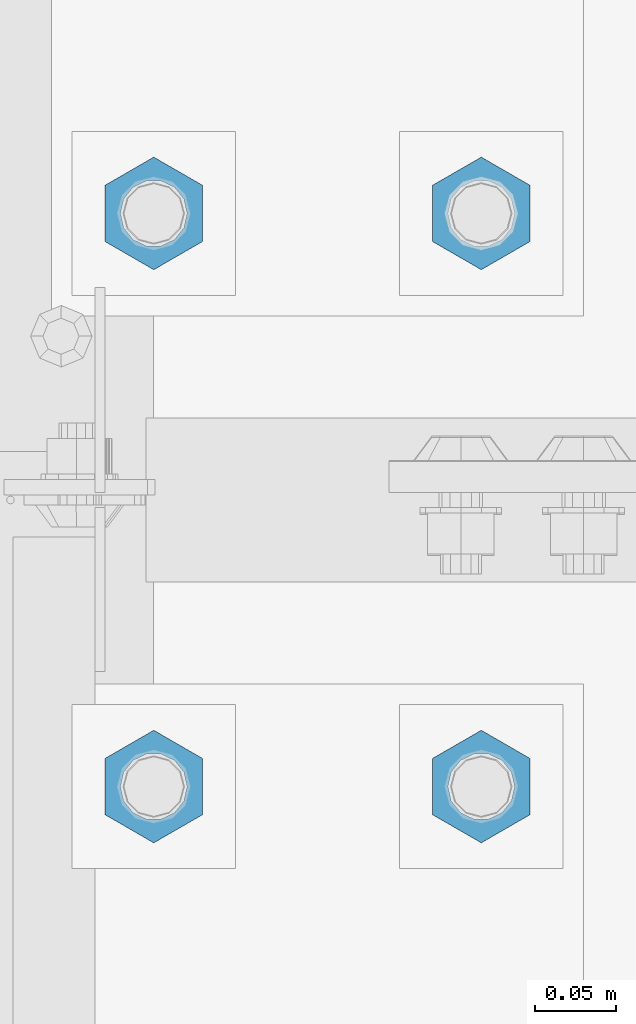
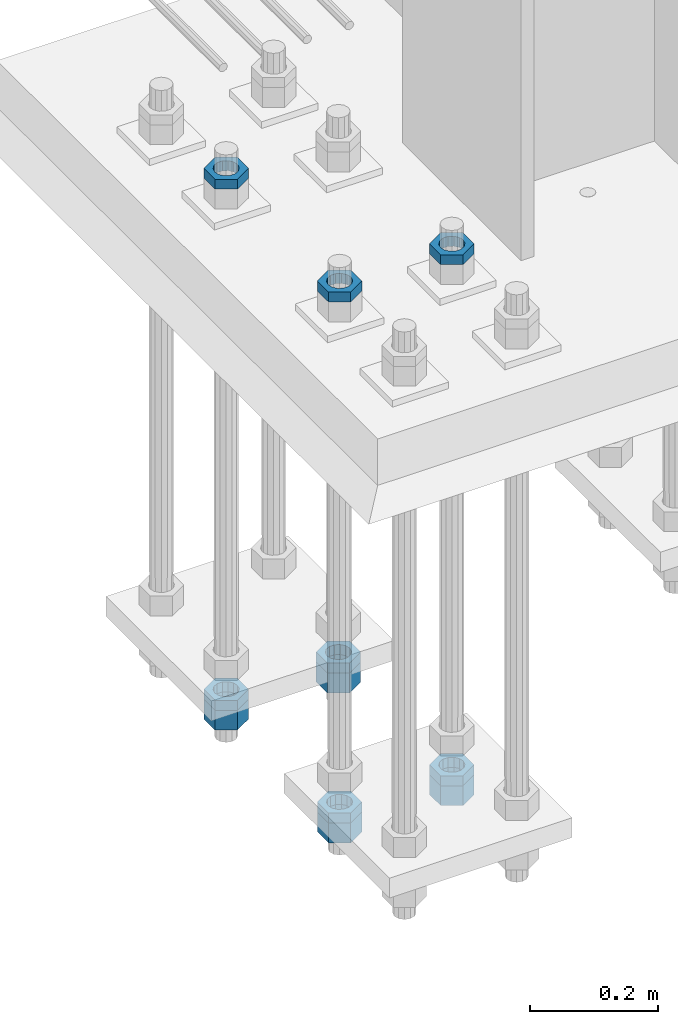
# One storey, part 2804 of 3843: 11 beams, 1 element without a shape of its own.
"""IFC2X3 building model written with IfcOpenShell, lengths in millimetres."""

from ifc_helpers import new_model, si_unit, frame, origin_with_axes, place, context, subcontext, project, spatial, faceted_brep, material, type_object, element, aggregate, save


model = new_model("IFC2X3")

# Units and contexts
model_context = context("Model", 3, precision=1e-05, world=origin_with_axes())
body_context = subcontext(model_context, "Body", "Model", "MODEL_VIEW")
ifc_project = project(units=[si_unit("LENGTHUNIT", "METRE", prefix="MILLI"), si_unit("AREAUNIT", "SQUARE_METRE"), si_unit("VOLUMEUNIT", "CUBIC_METRE"), si_unit("MASSUNIT", "GRAM", prefix="KILO"), si_unit("TIMEUNIT", "SECOND"), si_unit("PLANEANGLEUNIT", "RADIAN"), si_unit("SOLIDANGLEUNIT", "STERADIAN"), si_unit("THERMODYNAMICTEMPERATUREUNIT", "DEGREE_CELSIUS"), si_unit("LUMINOUSINTENSITYUNIT", "LUMEN")], contexts=[model_context])

# Site, building, storey
site_placement = place(None, origin_with_axes())
site = spatial("IfcSite", under=ifc_project, at=site_placement, CompositionType="ELEMENT")
building_placement = place(site_placement, origin_with_axes())
building = spatial("IfcBuilding", under=site, at=building_placement, Name="Undefined", CompositionType="ELEMENT")
storey_placement = place(building_placement, origin_with_axes())
storey = spatial("IfcBuildingStorey", under=building, at=storey_placement, Name="Undefined", CompositionType="ELEMENT", Elevation=0.0)

# Assembly, beams
assembly_placement = place(storey_placement, origin_with_axes())
assembly = element("IfcElementAssembly", 1, at=assembly_placement, inside=storey, Name="TEMPLATE", AssemblyPlace="NOTDEFINED", PredefinedType="RIGID_FRAME")
ifc_material = material(Name="STEEL/A572-50")
beam_type_1 = type_object("IfcBeamType", Name="1-1/2_HEAVY_HEX_NUT", PredefinedType="NOTDEFINED")
beam_1_placement = place(assembly_placement, frame((76504.799987793, 14820.8999969482, 29203.6500015259), z_axis=(1.0, 0.0, 0.0), x_axis=(0.0, 0.0, -1.0)))
beam_1 = element("IfcBeam", 2, at=beam_1_placement, type_object=beam_type_1, material=ifc_material, Name="NUT", ObjectType="1-1/2_HEAVY_HEX_NUT", context=body_context, shape_type="Brep", body=[
    faceted_brep([(0.0, -34.9199981689453, 0.0), (0.0, -17.4599990844727, -30.25), (38.0999999999985, -17.4599990844727, -30.25), (38.0999999999985, -34.9199981689453, 0.0), (0.0, 17.4599990844727, -30.25), (38.0999999999985, 17.4599990844727, -30.25), (0.0, 34.9199981689453, 0.0), (38.0999999999985, 34.9199981689453, 0.0), (0.0, 17.4599990844727, 30.25), (38.0999999999985, 17.4599990844727, 30.25), (0.0, -17.4599990844727, 30.25), (38.0999999999985, -17.4599990844727, 30.25), (0.0, 0.0, 20.6399993896484), (0.0, 8.9553601105581, 18.5959968835959), (38.0999999999985, 8.9553601105581, 18.5959968835959), (38.0999999999985, 0.0, 20.6399993896484), (0.0, 16.1370013209525, 12.8688291298167), (38.0999999999985, 16.1370013209525, 12.8688291298167), (0.0, 20.1225115123816, 4.59283194104501), (38.0999999999985, 20.1225115123816, 4.59283194104501), (0.0, 20.1225115123816, -4.59283194104501), (38.0999999999985, 20.1225115123816, -4.59283194104501), (0.0, 16.1370013209525, -12.8688291298167), (38.0999999999985, 16.1370013209525, -12.8688291298167), (0.0, 8.9553601105581, -18.5959968835959), (38.0999999999985, 8.9553601105581, -18.5959968835959), (0.0, 0.0, -20.6399993896484), (38.0999999999985, 0.0, -20.6399993896484), (0.0, -8.9553601105581, -18.5959968835959), (38.0999999999985, -8.9553601105581, -18.5959968835959), (0.0, -16.1370013209525, -12.8688291298167), (38.0999999999985, -16.1370013209525, -12.8688291298167), (0.0, -20.1225115123816, -4.59283194104501), (38.0999999999985, -20.1225115123816, -4.59283194104501), (0.0, -20.1225115123816, 4.59283194104501), (38.0999999999985, -20.1225115123816, 4.59283194104501), (0.0, -16.1370013209525, 12.8688291298167), (38.0999999999985, -16.1370013209525, 12.8688291298167), (0.0, -8.9553601105581, 18.5959968835959), (38.0999999999985, -8.9553601105581, 18.5959968835959)], [[[0, 1, 2, 3]], [[1, 4, 5, 2]], [[4, 6, 7, 5]], [[6, 8, 9, 7]], [[8, 10, 11, 9]], [[10, 0, 3, 11]], [[12, 13, 14, 15]], [[13, 16, 17, 14]], [[16, 18, 19, 17]], [[18, 20, 21, 19]], [[20, 22, 23, 21]], [[22, 24, 25, 23]], [[24, 26, 27, 25]], [[26, 28, 29, 27]], [[28, 30, 31, 29]], [[30, 32, 33, 31]], [[32, 34, 35, 33]], [[34, 36, 37, 35]], [[36, 38, 39, 37]], [[38, 12, 15, 39]], [[5, 7, 9, 11, 3, 2], [17, 19, 21, 23, 25, 27, 29, 31, 33, 35, 37, 39, 15, 14]], [[10, 8, 6, 4, 1, 0], [38, 36, 34, 32, 30, 28, 26, 24, 22, 20, 18, 16, 13, 12]]]),
])
beam_2_placement = place(assembly_placement, frame((76708.0, 14820.8999969482, 29203.6500015259), z_axis=(1.0, 0.0, 0.0), x_axis=(0.0, 0.0, -1.0)))
beam_2 = element("IfcBeam", 3, at=beam_2_placement, type_object=beam_type_1, material=ifc_material, Name="NUT", ObjectType="1-1/2_HEAVY_HEX_NUT", context=body_context, shape_type="Brep", body=[
    faceted_brep([(0.0, -34.9199981689453, 0.0), (0.0, -17.4599990844727, -30.25), (38.0999999999985, -17.4599990844727, -30.25), (38.0999999999985, -34.9199981689453, 0.0), (0.0, 17.4599990844727, -30.25), (38.0999999999985, 17.4599990844727, -30.25), (0.0, 34.9199981689453, 0.0), (38.0999999999985, 34.9199981689453, 0.0), (0.0, 17.4599990844727, 30.25), (38.0999999999985, 17.4599990844727, 30.25), (0.0, -17.4599990844727, 30.25), (38.0999999999985, -17.4599990844727, 30.25), (0.0, 0.0, 20.6399993896484), (0.0, 8.9553601105581, 18.5959968835959), (38.0999999999985, 8.9553601105581, 18.5959968835959), (38.0999999999985, 0.0, 20.6399993896484), (0.0, 16.1370013209525, 12.8688291298167), (38.0999999999985, 16.1370013209525, 12.8688291298167), (0.0, 20.1225115123816, 4.59283194104501), (38.0999999999985, 20.1225115123816, 4.59283194104501), (0.0, 20.1225115123816, -4.59283194104501), (38.0999999999985, 20.1225115123816, -4.59283194104501), (0.0, 16.1370013209525, -12.8688291298167), (38.0999999999985, 16.1370013209525, -12.8688291298167), (0.0, 8.9553601105581, -18.5959968835959), (38.0999999999985, 8.9553601105581, -18.5959968835959), (0.0, 0.0, -20.6399993896484), (38.0999999999985, 0.0, -20.6399993896484), (0.0, -8.9553601105581, -18.5959968835959), (38.0999999999985, -8.9553601105581, -18.5959968835959), (0.0, -16.1370013209525, -12.8688291298167), (38.0999999999985, -16.1370013209525, -12.8688291298167), (0.0, -20.1225115123816, -4.59283194104501), (38.0999999999985, -20.1225115123816, -4.59283194104501), (0.0, -20.1225115123816, 4.59283194104501), (38.0999999999985, -20.1225115123816, 4.59283194104501), (0.0, -16.1370013209525, 12.8688291298167), (38.0999999999985, -16.1370013209525, 12.8688291298167), (0.0, -8.9553601105581, 18.5959968835959), (38.0999999999985, -8.9553601105581, 18.5959968835959)], [[[0, 1, 2, 3]], [[1, 4, 5, 2]], [[4, 6, 7, 5]], [[6, 8, 9, 7]], [[8, 10, 11, 9]], [[10, 0, 3, 11]], [[12, 13, 14, 15]], [[13, 16, 17, 14]], [[16, 18, 19, 17]], [[18, 20, 21, 19]], [[20, 22, 23, 21]], [[22, 24, 25, 23]], [[24, 26, 27, 25]], [[26, 28, 29, 27]], [[28, 30, 31, 29]], [[30, 32, 33, 31]], [[32, 34, 35, 33]], [[34, 36, 37, 35]], [[36, 38, 39, 37]], [[38, 12, 15, 39]], [[5, 7, 9, 11, 3, 2], [17, 19, 21, 23, 25, 27, 29, 31, 33, 35, 37, 39, 15, 14]], [[10, 8, 6, 4, 1, 0], [38, 36, 34, 32, 30, 28, 26, 24, 22, 20, 18, 16, 13, 12]]]),
])
beam_3_placement = place(assembly_placement, frame((76504.799987793, 15176.5, 29203.6500015259), z_axis=(1.0, 0.0, 0.0), x_axis=(0.0, 0.0, -1.0)))
beam_3 = element("IfcBeam", 4, at=beam_3_placement, type_object=beam_type_1, material=ifc_material, Name="NUT", ObjectType="1-1/2_HEAVY_HEX_NUT", context=body_context, shape_type="Brep", body=[
    faceted_brep([(0.0, -34.9199981689453, 0.0), (0.0, -17.4599990844727, -30.25), (38.0999999999985, -17.4599990844727, -30.25), (38.0999999999985, -34.9199981689453, 0.0), (0.0, 17.4599990844727, -30.25), (38.0999999999985, 17.4599990844727, -30.25), (0.0, 34.9199981689453, 0.0), (38.0999999999985, 34.9199981689453, 0.0), (0.0, 17.4599990844727, 30.25), (38.0999999999985, 17.4599990844727, 30.25), (0.0, -17.4599990844727, 30.25), (38.0999999999985, -17.4599990844727, 30.25), (0.0, 0.0, 20.6399993896484), (0.0, 8.9553601105581, 18.5959968835959), (38.0999999999985, 8.9553601105581, 18.5959968835959), (38.0999999999985, 0.0, 20.6399993896484), (0.0, 16.1370013209525, 12.8688291298167), (38.0999999999985, 16.1370013209525, 12.8688291298167), (0.0, 20.1225115123816, 4.59283194104501), (38.0999999999985, 20.1225115123816, 4.59283194104501), (0.0, 20.1225115123816, -4.59283194104501), (38.0999999999985, 20.1225115123816, -4.59283194104501), (0.0, 16.1370013209525, -12.8688291298167), (38.0999999999985, 16.1370013209525, -12.8688291298167), (0.0, 8.9553601105581, -18.5959968835959), (38.0999999999985, 8.9553601105581, -18.5959968835959), (0.0, 0.0, -20.6399993896484), (38.0999999999985, 0.0, -20.6399993896484), (0.0, -8.9553601105581, -18.5959968835959), (38.0999999999985, -8.9553601105581, -18.5959968835959), (0.0, -16.1370013209525, -12.8688291298167), (38.0999999999985, -16.1370013209525, -12.8688291298167), (0.0, -20.1225115123816, -4.59283194104501), (38.0999999999985, -20.1225115123816, -4.59283194104501), (0.0, -20.1225115123816, 4.59283194104501), (38.0999999999985, -20.1225115123816, 4.59283194104501), (0.0, -16.1370013209525, 12.8688291298167), (38.0999999999985, -16.1370013209525, 12.8688291298167), (0.0, -8.9553601105581, 18.5959968835959), (38.0999999999985, -8.9553601105581, 18.5959968835959)], [[[0, 1, 2, 3]], [[1, 4, 5, 2]], [[4, 6, 7, 5]], [[6, 8, 9, 7]], [[8, 10, 11, 9]], [[10, 0, 3, 11]], [[12, 13, 14, 15]], [[13, 16, 17, 14]], [[16, 18, 19, 17]], [[18, 20, 21, 19]], [[20, 22, 23, 21]], [[22, 24, 25, 23]], [[24, 26, 27, 25]], [[26, 28, 29, 27]], [[28, 30, 31, 29]], [[30, 32, 33, 31]], [[32, 34, 35, 33]], [[34, 36, 37, 35]], [[36, 38, 39, 37]], [[38, 12, 15, 39]], [[5, 7, 9, 11, 3, 2], [17, 19, 21, 23, 25, 27, 29, 31, 33, 35, 37, 39, 15, 14]], [[10, 8, 6, 4, 1, 0], [38, 36, 34, 32, 30, 28, 26, 24, 22, 20, 18, 16, 13, 12]]]),
])
beam_4_placement = place(assembly_placement, frame((76708.0, 15176.5, 29203.6500015259), z_axis=(1.0, 0.0, 0.0), x_axis=(0.0, 0.0, -1.0)))
beam_4 = element("IfcBeam", 5, at=beam_4_placement, type_object=beam_type_1, material=ifc_material, Name="NUT", ObjectType="1-1/2_HEAVY_HEX_NUT", context=body_context, shape_type="Brep", body=[
    faceted_brep([(0.0, -34.9199981689453, 0.0), (0.0, -17.4599990844727, -30.25), (38.0999999999985, -17.4599990844727, -30.25), (38.0999999999985, -34.9199981689453, 0.0), (0.0, 17.4599990844727, -30.25), (38.0999999999985, 17.4599990844727, -30.25), (0.0, 34.9199981689453, 0.0), (38.0999999999985, 34.9199981689453, 0.0), (0.0, 17.4599990844727, 30.25), (38.0999999999985, 17.4599990844727, 30.25), (0.0, -17.4599990844727, 30.25), (38.0999999999985, -17.4599990844727, 30.25), (0.0, 0.0, 20.6399993896484), (0.0, 8.9553601105581, 18.5959968835959), (38.0999999999985, 8.9553601105581, 18.5959968835959), (38.0999999999985, 0.0, 20.6399993896484), (0.0, 16.1370013209525, 12.8688291298167), (38.0999999999985, 16.1370013209525, 12.8688291298167), (0.0, 20.1225115123816, 4.59283194104501), (38.0999999999985, 20.1225115123816, 4.59283194104501), (0.0, 20.1225115123816, -4.59283194104501), (38.0999999999985, 20.1225115123816, -4.59283194104501), (0.0, 16.1370013209525, -12.8688291298167), (38.0999999999985, 16.1370013209525, -12.8688291298167), (0.0, 8.9553601105581, -18.5959968835959), (38.0999999999985, 8.9553601105581, -18.5959968835959), (0.0, 0.0, -20.6399993896484), (38.0999999999985, 0.0, -20.6399993896484), (0.0, -8.9553601105581, -18.5959968835959), (38.0999999999985, -8.9553601105581, -18.5959968835959), (0.0, -16.1370013209525, -12.8688291298167), (38.0999999999985, -16.1370013209525, -12.8688291298167), (0.0, -20.1225115123816, -4.59283194104501), (38.0999999999985, -20.1225115123816, -4.59283194104501), (0.0, -20.1225115123816, 4.59283194104501), (38.0999999999985, -20.1225115123816, 4.59283194104501), (0.0, -16.1370013209525, 12.8688291298167), (38.0999999999985, -16.1370013209525, 12.8688291298167), (0.0, -8.9553601105581, 18.5959968835959), (38.0999999999985, -8.9553601105581, 18.5959968835959)], [[[0, 1, 2, 3]], [[1, 4, 5, 2]], [[4, 6, 7, 5]], [[6, 8, 9, 7]], [[8, 10, 11, 9]], [[10, 0, 3, 11]], [[12, 13, 14, 15]], [[13, 16, 17, 14]], [[16, 18, 19, 17]], [[18, 20, 21, 19]], [[20, 22, 23, 21]], [[22, 24, 25, 23]], [[24, 26, 27, 25]], [[26, 28, 29, 27]], [[28, 30, 31, 29]], [[30, 32, 33, 31]], [[32, 34, 35, 33]], [[34, 36, 37, 35]], [[36, 38, 39, 37]], [[38, 12, 15, 39]], [[5, 7, 9, 11, 3, 2], [17, 19, 21, 23, 25, 27, 29, 31, 33, 35, 37, 39, 15, 14]], [[10, 8, 6, 4, 1, 0], [38, 36, 34, 32, 30, 28, 26, 24, 22, 20, 18, 16, 13, 12]]]),
])
beam_type_2 = type_object("IfcBeamType", Name="1-1/2_HALF_NUT", PredefinedType="NOTDEFINED")
beam_5_placement = place(assembly_placement, frame((76504.799987793, 14820.8999969482, 29222.7), z_axis=(1.0, 0.0, 0.0), x_axis=(0.0, 0.0, -1.0)))
beam_5 = element("IfcBeam", 6, at=beam_5_placement, type_object=beam_type_2, material=ifc_material, Name="NUT", ObjectType="1-1/2_HALF_NUT", context=body_context, shape_type="Brep", body=[
    faceted_brep([(0.0, -34.9199981689453, 0.0), (0.0, -17.4599990844727, -30.25), (19.0500000000029, -17.4599990844727, -30.25), (19.0500000000029, -34.9199981689453, 0.0), (0.0, 17.4599990844727, -30.25), (19.0500000000029, 17.4599990844727, -30.25), (0.0, 34.9199981689453, 0.0), (19.0500000000029, 34.9199981689453, 0.0), (0.0, 17.4599990844727, 30.25), (19.0500000000029, 17.4599990844727, 30.25), (0.0, -17.4599990844727, 30.25), (19.0500000000029, -17.4599990844727, 30.25), (0.0, 0.0, 20.6399993896484), (0.0, 8.9553601105581, 18.5959968835959), (19.0500000000029, 8.95536011056538, 18.5959968835959), (19.0500000000029, 0.0, 20.6399993896484), (0.0, 16.1370013209525, 12.8688291298167), (19.0500000000029, 16.1370013209489, 12.8688291298167), (0.0, 20.1225115123816, 4.59283194104501), (19.0500000000029, 20.1225115123852, 4.59283194104501), (0.0, 20.1225115123816, -4.59283194104501), (19.0500000000029, 20.1225115123852, -4.59283194104501), (0.0, 16.1370013209525, -12.8688291298167), (19.0500000000029, 16.1370013209489, -12.8688291298167), (0.0, 8.9553601105581, -18.5959968835959), (19.0500000000029, 8.95536011056538, -18.5959968835959), (0.0, 0.0, -20.6399993896484), (19.0500000000029, 0.0, -20.6399993896484), (0.0, -8.9553601105581, -18.5959968835959), (19.0500000000029, -8.95536011056538, -18.5959968835959), (0.0, -16.1370013209525, -12.8688291298167), (19.0500000000029, -16.1370013209489, -12.8688291298167), (0.0, -20.1225115123816, -4.59283194104501), (19.0500000000029, -20.1225115123852, -4.59283194104501), (0.0, -20.1225115123816, 4.59283194104501), (19.0500000000029, -20.1225115123852, 4.59283194104501), (0.0, -16.1370013209525, 12.8688291298167), (19.0500000000029, -16.1370013209489, 12.8688291298167), (0.0, -8.9553601105581, 18.5959968835959), (19.0500000000029, -8.95536011056538, 18.5959968835959)], [[[0, 1, 2, 3]], [[1, 4, 5, 2]], [[4, 6, 7, 5]], [[6, 8, 9, 7]], [[8, 10, 11, 9]], [[10, 0, 3, 11]], [[12, 13, 14, 15]], [[13, 16, 17, 14]], [[16, 18, 19, 17]], [[18, 20, 21, 19]], [[20, 22, 23, 21]], [[22, 24, 25, 23]], [[24, 26, 27, 25]], [[26, 28, 29, 27]], [[28, 30, 31, 29]], [[30, 32, 33, 31]], [[32, 34, 35, 33]], [[34, 36, 37, 35]], [[36, 38, 39, 37]], [[38, 12, 15, 39]], [[5, 7, 9, 11, 3, 2], [17, 19, 21, 23, 25, 27, 29, 31, 33, 35, 37, 39, 15, 14]], [[10, 8, 6, 4, 1, 0], [38, 36, 34, 32, 30, 28, 26, 24, 22, 20, 18, 16, 13, 12]]]),
])
beam_6_placement = place(assembly_placement, frame((76504.799987793, 14820.8999969482, 30219.65), z_axis=(1.0, 0.0, 0.0), x_axis=(0.0, 0.0, -1.0)))
beam_6 = element("IfcBeam", 7, at=beam_6_placement, type_object=beam_type_2, material=ifc_material, Name="NUT", ObjectType="1-1/2_HALF_NUT", context=body_context, shape_type="Brep", body=[
    faceted_brep([(0.0, -34.9199981689453, 0.0), (0.0, -17.4599990844727, -30.25), (19.0500000000029, -17.4599990844727, -30.25), (19.0500000000029, -34.9199981689453, 0.0), (0.0, 17.4599990844727, -30.25), (19.0500000000029, 17.4599990844727, -30.25), (0.0, 34.9199981689453, 0.0), (19.0500000000029, 34.9199981689453, 0.0), (0.0, 17.4599990844727, 30.25), (19.0500000000029, 17.4599990844727, 30.25), (0.0, -17.4599990844727, 30.25), (19.0500000000029, -17.4599990844727, 30.25), (0.0, 0.0, 20.6399993896484), (0.0, 8.9553601105581, 18.5959968835959), (19.0500000000029, 8.95536011056538, 18.5959968835959), (19.0500000000029, 0.0, 20.6399993896484), (0.0, 16.1370013209525, 12.8688291298167), (19.0500000000029, 16.1370013209489, 12.8688291298167), (0.0, 20.1225115123816, 4.59283194104501), (19.0500000000029, 20.1225115123852, 4.59283194104501), (0.0, 20.1225115123816, -4.59283194104501), (19.0500000000029, 20.1225115123852, -4.59283194104501), (0.0, 16.1370013209525, -12.8688291298167), (19.0500000000029, 16.1370013209489, -12.8688291298167), (0.0, 8.9553601105581, -18.5959968835959), (19.0500000000029, 8.95536011056538, -18.5959968835959), (0.0, 0.0, -20.6399993896484), (19.0500000000029, 0.0, -20.6399993896484), (0.0, -8.9553601105581, -18.5959968835959), (19.0500000000029, -8.95536011056538, -18.5959968835959), (0.0, -16.1370013209525, -12.8688291298167), (19.0500000000029, -16.1370013209489, -12.8688291298167), (0.0, -20.1225115123816, -4.59283194104501), (19.0500000000029, -20.1225115123852, -4.59283194104501), (0.0, -20.1225115123816, 4.59283194104501), (19.0500000000029, -20.1225115123852, 4.59283194104501), (0.0, -16.1370013209525, 12.8688291298167), (19.0500000000029, -16.1370013209489, 12.8688291298167), (0.0, -8.9553601105581, 18.5959968835959), (19.0500000000029, -8.95536011056538, 18.5959968835959)], [[[0, 1, 2, 3]], [[1, 4, 5, 2]], [[4, 6, 7, 5]], [[6, 8, 9, 7]], [[8, 10, 11, 9]], [[10, 0, 3, 11]], [[12, 13, 14, 15]], [[13, 16, 17, 14]], [[16, 18, 19, 17]], [[18, 20, 21, 19]], [[20, 22, 23, 21]], [[22, 24, 25, 23]], [[24, 26, 27, 25]], [[26, 28, 29, 27]], [[28, 30, 31, 29]], [[30, 32, 33, 31]], [[32, 34, 35, 33]], [[34, 36, 37, 35]], [[36, 38, 39, 37]], [[38, 12, 15, 39]], [[5, 7, 9, 11, 3, 2], [17, 19, 21, 23, 25, 27, 29, 31, 33, 35, 37, 39, 15, 14]], [[10, 8, 6, 4, 1, 0], [38, 36, 34, 32, 30, 28, 26, 24, 22, 20, 18, 16, 13, 12]]]),
])
beam_7_placement = place(assembly_placement, frame((76708.0, 14820.8999969482, 29222.7), z_axis=(1.0, 0.0, 0.0), x_axis=(0.0, 0.0, -1.0)))
beam_7 = element("IfcBeam", 8, at=beam_7_placement, type_object=beam_type_2, material=ifc_material, Name="NUT", ObjectType="1-1/2_HALF_NUT", context=body_context, shape_type="Brep", body=[
    faceted_brep([(0.0, -34.9199981689453, 0.0), (0.0, -17.4599990844727, -30.25), (19.0500000000029, -17.4599990844727, -30.25), (19.0500000000029, -34.9199981689453, 0.0), (0.0, 17.4599990844727, -30.25), (19.0500000000029, 17.4599990844727, -30.25), (0.0, 34.9199981689453, 0.0), (19.0500000000029, 34.9199981689453, 0.0), (0.0, 17.4599990844727, 30.25), (19.0500000000029, 17.4599990844727, 30.25), (0.0, -17.4599990844727, 30.25), (19.0500000000029, -17.4599990844727, 30.25), (0.0, 0.0, 20.6399993896484), (0.0, 8.9553601105581, 18.5959968835959), (19.0500000000029, 8.95536011056538, 18.5959968835959), (19.0500000000029, 0.0, 20.6399993896484), (0.0, 16.1370013209525, 12.8688291298167), (19.0500000000029, 16.1370013209489, 12.8688291298167), (0.0, 20.1225115123816, 4.59283194104501), (19.0500000000029, 20.1225115123852, 4.59283194104501), (0.0, 20.1225115123816, -4.59283194104501), (19.0500000000029, 20.1225115123852, -4.59283194104501), (0.0, 16.1370013209525, -12.8688291298167), (19.0500000000029, 16.1370013209489, -12.8688291298167), (0.0, 8.9553601105581, -18.5959968835959), (19.0500000000029, 8.95536011056538, -18.5959968835959), (0.0, 0.0, -20.6399993896484), (19.0500000000029, 0.0, -20.6399993896484), (0.0, -8.9553601105581, -18.5959968835959), (19.0500000000029, -8.95536011056538, -18.5959968835959), (0.0, -16.1370013209525, -12.8688291298167), (19.0500000000029, -16.1370013209489, -12.8688291298167), (0.0, -20.1225115123816, -4.59283194104501), (19.0500000000029, -20.1225115123852, -4.59283194104501), (0.0, -20.1225115123816, 4.59283194104501), (19.0500000000029, -20.1225115123852, 4.59283194104501), (0.0, -16.1370013209525, 12.8688291298167), (19.0500000000029, -16.1370013209489, 12.8688291298167), (0.0, -8.9553601105581, 18.5959968835959), (19.0500000000029, -8.95536011056538, 18.5959968835959)], [[[0, 1, 2, 3]], [[1, 4, 5, 2]], [[4, 6, 7, 5]], [[6, 8, 9, 7]], [[8, 10, 11, 9]], [[10, 0, 3, 11]], [[12, 13, 14, 15]], [[13, 16, 17, 14]], [[16, 18, 19, 17]], [[18, 20, 21, 19]], [[20, 22, 23, 21]], [[22, 24, 25, 23]], [[24, 26, 27, 25]], [[26, 28, 29, 27]], [[28, 30, 31, 29]], [[30, 32, 33, 31]], [[32, 34, 35, 33]], [[34, 36, 37, 35]], [[36, 38, 39, 37]], [[38, 12, 15, 39]], [[5, 7, 9, 11, 3, 2], [17, 19, 21, 23, 25, 27, 29, 31, 33, 35, 37, 39, 15, 14]], [[10, 8, 6, 4, 1, 0], [38, 36, 34, 32, 30, 28, 26, 24, 22, 20, 18, 16, 13, 12]]]),
])
beam_8_placement = place(assembly_placement, frame((76708.0, 14820.8999969482, 30219.65), z_axis=(1.0, 0.0, 0.0), x_axis=(0.0, 0.0, -1.0)))
beam_8 = element("IfcBeam", 9, at=beam_8_placement, type_object=beam_type_2, material=ifc_material, Name="NUT", ObjectType="1-1/2_HALF_NUT", context=body_context, shape_type="Brep", body=[
    faceted_brep([(0.0, -34.9199981689453, 0.0), (0.0, -17.4599990844727, -30.25), (19.0500000000029, -17.4599990844727, -30.25), (19.0500000000029, -34.9199981689453, 0.0), (0.0, 17.4599990844727, -30.25), (19.0500000000029, 17.4599990844727, -30.25), (0.0, 34.9199981689453, 0.0), (19.0500000000029, 34.9199981689453, 0.0), (0.0, 17.4599990844727, 30.25), (19.0500000000029, 17.4599990844727, 30.25), (0.0, -17.4599990844727, 30.25), (19.0500000000029, -17.4599990844727, 30.25), (0.0, 0.0, 20.6399993896484), (0.0, 8.9553601105581, 18.5959968835959), (19.0500000000029, 8.95536011056538, 18.5959968835959), (19.0500000000029, 0.0, 20.6399993896484), (0.0, 16.1370013209525, 12.8688291298167), (19.0500000000029, 16.1370013209489, 12.8688291298167), (0.0, 20.1225115123816, 4.59283194104501), (19.0500000000029, 20.1225115123852, 4.59283194104501), (0.0, 20.1225115123816, -4.59283194104501), (19.0500000000029, 20.1225115123852, -4.59283194104501), (0.0, 16.1370013209525, -12.8688291298167), (19.0500000000029, 16.1370013209489, -12.8688291298167), (0.0, 8.9553601105581, -18.5959968835959), (19.0500000000029, 8.95536011056538, -18.5959968835959), (0.0, 0.0, -20.6399993896484), (19.0500000000029, 0.0, -20.6399993896484), (0.0, -8.9553601105581, -18.5959968835959), (19.0500000000029, -8.95536011056538, -18.5959968835959), (0.0, -16.1370013209525, -12.8688291298167), (19.0500000000029, -16.1370013209489, -12.8688291298167), (0.0, -20.1225115123816, -4.59283194104501), (19.0500000000029, -20.1225115123852, -4.59283194104501), (0.0, -20.1225115123816, 4.59283194104501), (19.0500000000029, -20.1225115123852, 4.59283194104501), (0.0, -16.1370013209525, 12.8688291298167), (19.0500000000029, -16.1370013209489, 12.8688291298167), (0.0, -8.9553601105581, 18.5959968835959), (19.0500000000029, -8.95536011056538, 18.5959968835959)], [[[0, 1, 2, 3]], [[1, 4, 5, 2]], [[4, 6, 7, 5]], [[6, 8, 9, 7]], [[8, 10, 11, 9]], [[10, 0, 3, 11]], [[12, 13, 14, 15]], [[13, 16, 17, 14]], [[16, 18, 19, 17]], [[18, 20, 21, 19]], [[20, 22, 23, 21]], [[22, 24, 25, 23]], [[24, 26, 27, 25]], [[26, 28, 29, 27]], [[28, 30, 31, 29]], [[30, 32, 33, 31]], [[32, 34, 35, 33]], [[34, 36, 37, 35]], [[36, 38, 39, 37]], [[38, 12, 15, 39]], [[5, 7, 9, 11, 3, 2], [17, 19, 21, 23, 25, 27, 29, 31, 33, 35, 37, 39, 15, 14]], [[10, 8, 6, 4, 1, 0], [38, 36, 34, 32, 30, 28, 26, 24, 22, 20, 18, 16, 13, 12]]]),
])
beam_9_placement = place(assembly_placement, frame((76504.799987793, 15176.5, 29222.7), z_axis=(1.0, 0.0, 0.0), x_axis=(0.0, 0.0, -1.0)))
beam_9 = element("IfcBeam", 10, at=beam_9_placement, type_object=beam_type_2, material=ifc_material, Name="NUT", ObjectType="1-1/2_HALF_NUT", context=body_context, shape_type="Brep", body=[
    faceted_brep([(0.0, -34.9199981689453, 0.0), (0.0, -17.4599990844727, -30.25), (19.0500000000029, -17.4599990844727, -30.25), (19.0500000000029, -34.9199981689453, 0.0), (0.0, 17.4599990844727, -30.25), (19.0500000000029, 17.4599990844727, -30.25), (0.0, 34.9199981689453, 0.0), (19.0500000000029, 34.9199981689453, 0.0), (0.0, 17.4599990844727, 30.25), (19.0500000000029, 17.4599990844727, 30.25), (0.0, -17.4599990844727, 30.25), (19.0500000000029, -17.4599990844727, 30.25), (0.0, 0.0, 20.6399993896484), (0.0, 8.9553601105581, 18.5959968835959), (19.0500000000029, 8.95536011056538, 18.5959968835959), (19.0500000000029, 0.0, 20.6399993896484), (0.0, 16.1370013209525, 12.8688291298167), (19.0500000000029, 16.1370013209489, 12.8688291298167), (0.0, 20.1225115123816, 4.59283194104501), (19.0500000000029, 20.1225115123852, 4.59283194104501), (0.0, 20.1225115123816, -4.59283194104501), (19.0500000000029, 20.1225115123852, -4.59283194104501), (0.0, 16.1370013209525, -12.8688291298167), (19.0500000000029, 16.1370013209489, -12.8688291298167), (0.0, 8.9553601105581, -18.5959968835959), (19.0500000000029, 8.95536011056538, -18.5959968835959), (0.0, 0.0, -20.6399993896484), (19.0500000000029, 0.0, -20.6399993896484), (0.0, -8.9553601105581, -18.5959968835959), (19.0500000000029, -8.95536011056538, -18.5959968835959), (0.0, -16.1370013209525, -12.8688291298167), (19.0500000000029, -16.1370013209489, -12.8688291298167), (0.0, -20.1225115123816, -4.59283194104501), (19.0500000000029, -20.1225115123852, -4.59283194104501), (0.0, -20.1225115123816, 4.59283194104501), (19.0500000000029, -20.1225115123852, 4.59283194104501), (0.0, -16.1370013209525, 12.8688291298167), (19.0500000000029, -16.1370013209489, 12.8688291298167), (0.0, -8.9553601105581, 18.5959968835959), (19.0500000000029, -8.95536011056538, 18.5959968835959)], [[[0, 1, 2, 3]], [[1, 4, 5, 2]], [[4, 6, 7, 5]], [[6, 8, 9, 7]], [[8, 10, 11, 9]], [[10, 0, 3, 11]], [[12, 13, 14, 15]], [[13, 16, 17, 14]], [[16, 18, 19, 17]], [[18, 20, 21, 19]], [[20, 22, 23, 21]], [[22, 24, 25, 23]], [[24, 26, 27, 25]], [[26, 28, 29, 27]], [[28, 30, 31, 29]], [[30, 32, 33, 31]], [[32, 34, 35, 33]], [[34, 36, 37, 35]], [[36, 38, 39, 37]], [[38, 12, 15, 39]], [[5, 7, 9, 11, 3, 2], [17, 19, 21, 23, 25, 27, 29, 31, 33, 35, 37, 39, 15, 14]], [[10, 8, 6, 4, 1, 0], [38, 36, 34, 32, 30, 28, 26, 24, 22, 20, 18, 16, 13, 12]]]),
])
beam_10_placement = place(assembly_placement, frame((76504.799987793, 15176.5, 30219.65), z_axis=(1.0, 0.0, 0.0), x_axis=(0.0, 0.0, -1.0)))
beam_10 = element("IfcBeam", 11, at=beam_10_placement, type_object=beam_type_2, material=ifc_material, Name="NUT", ObjectType="1-1/2_HALF_NUT", context=body_context, shape_type="Brep", body=[
    faceted_brep([(0.0, -34.9199981689453, 0.0), (0.0, -17.4599990844727, -30.25), (19.0500000000029, -17.4599990844727, -30.25), (19.0500000000029, -34.9199981689453, 0.0), (0.0, 17.4599990844727, -30.25), (19.0500000000029, 17.4599990844727, -30.25), (0.0, 34.9199981689453, 0.0), (19.0500000000029, 34.9199981689453, 0.0), (0.0, 17.4599990844727, 30.25), (19.0500000000029, 17.4599990844727, 30.25), (0.0, -17.4599990844727, 30.25), (19.0500000000029, -17.4599990844727, 30.25), (0.0, 0.0, 20.6399993896484), (0.0, 8.9553601105581, 18.5959968835959), (19.0500000000029, 8.95536011056538, 18.5959968835959), (19.0500000000029, 0.0, 20.6399993896484), (0.0, 16.1370013209525, 12.8688291298167), (19.0500000000029, 16.1370013209489, 12.8688291298167), (0.0, 20.1225115123816, 4.59283194104501), (19.0500000000029, 20.1225115123852, 4.59283194104501), (0.0, 20.1225115123816, -4.59283194104501), (19.0500000000029, 20.1225115123852, -4.59283194104501), (0.0, 16.1370013209525, -12.8688291298167), (19.0500000000029, 16.1370013209489, -12.8688291298167), (0.0, 8.9553601105581, -18.5959968835959), (19.0500000000029, 8.95536011056538, -18.5959968835959), (0.0, 0.0, -20.6399993896484), (19.0500000000029, 0.0, -20.6399993896484), (0.0, -8.9553601105581, -18.5959968835959), (19.0500000000029, -8.95536011056538, -18.5959968835959), (0.0, -16.1370013209525, -12.8688291298167), (19.0500000000029, -16.1370013209489, -12.8688291298167), (0.0, -20.1225115123816, -4.59283194104501), (19.0500000000029, -20.1225115123852, -4.59283194104501), (0.0, -20.1225115123816, 4.59283194104501), (19.0500000000029, -20.1225115123852, 4.59283194104501), (0.0, -16.1370013209525, 12.8688291298167), (19.0500000000029, -16.1370013209489, 12.8688291298167), (0.0, -8.9553601105581, 18.5959968835959), (19.0500000000029, -8.95536011056538, 18.5959968835959)], [[[0, 1, 2, 3]], [[1, 4, 5, 2]], [[4, 6, 7, 5]], [[6, 8, 9, 7]], [[8, 10, 11, 9]], [[10, 0, 3, 11]], [[12, 13, 14, 15]], [[13, 16, 17, 14]], [[16, 18, 19, 17]], [[18, 20, 21, 19]], [[20, 22, 23, 21]], [[22, 24, 25, 23]], [[24, 26, 27, 25]], [[26, 28, 29, 27]], [[28, 30, 31, 29]], [[30, 32, 33, 31]], [[32, 34, 35, 33]], [[34, 36, 37, 35]], [[36, 38, 39, 37]], [[38, 12, 15, 39]], [[5, 7, 9, 11, 3, 2], [17, 19, 21, 23, 25, 27, 29, 31, 33, 35, 37, 39, 15, 14]], [[10, 8, 6, 4, 1, 0], [38, 36, 34, 32, 30, 28, 26, 24, 22, 20, 18, 16, 13, 12]]]),
])
beam_11_placement = place(assembly_placement, frame((76708.0, 15176.5, 29222.7), z_axis=(1.0, 0.0, 0.0), x_axis=(0.0, 0.0, -1.0)))
beam_11 = element("IfcBeam", 12, at=beam_11_placement, type_object=beam_type_2, material=ifc_material, Name="NUT", ObjectType="1-1/2_HALF_NUT", context=body_context, shape_type="Brep", body=[
    faceted_brep([(0.0, -34.9199981689453, 0.0), (0.0, -17.4599990844727, -30.25), (19.0500000000029, -17.4599990844727, -30.25), (19.0500000000029, -34.9199981689453, 0.0), (0.0, 17.4599990844727, -30.25), (19.0500000000029, 17.4599990844727, -30.25), (0.0, 34.9199981689453, 0.0), (19.0500000000029, 34.9199981689453, 0.0), (0.0, 17.4599990844727, 30.25), (19.0500000000029, 17.4599990844727, 30.25), (0.0, -17.4599990844727, 30.25), (19.0500000000029, -17.4599990844727, 30.25), (0.0, 0.0, 20.6399993896484), (0.0, 8.9553601105581, 18.5959968835959), (19.0500000000029, 8.95536011056538, 18.5959968835959), (19.0500000000029, 0.0, 20.6399993896484), (0.0, 16.1370013209525, 12.8688291298167), (19.0500000000029, 16.1370013209489, 12.8688291298167), (0.0, 20.1225115123816, 4.59283194104501), (19.0500000000029, 20.1225115123852, 4.59283194104501), (0.0, 20.1225115123816, -4.59283194104501), (19.0500000000029, 20.1225115123852, -4.59283194104501), (0.0, 16.1370013209525, -12.8688291298167), (19.0500000000029, 16.1370013209489, -12.8688291298167), (0.0, 8.9553601105581, -18.5959968835959), (19.0500000000029, 8.95536011056538, -18.5959968835959), (0.0, 0.0, -20.6399993896484), (19.0500000000029, 0.0, -20.6399993896484), (0.0, -8.9553601105581, -18.5959968835959), (19.0500000000029, -8.95536011056538, -18.5959968835959), (0.0, -16.1370013209525, -12.8688291298167), (19.0500000000029, -16.1370013209489, -12.8688291298167), (0.0, -20.1225115123816, -4.59283194104501), (19.0500000000029, -20.1225115123852, -4.59283194104501), (0.0, -20.1225115123816, 4.59283194104501), (19.0500000000029, -20.1225115123852, 4.59283194104501), (0.0, -16.1370013209525, 12.8688291298167), (19.0500000000029, -16.1370013209489, 12.8688291298167), (0.0, -8.9553601105581, 18.5959968835959), (19.0500000000029, -8.95536011056538, 18.5959968835959)], [[[0, 1, 2, 3]], [[1, 4, 5, 2]], [[4, 6, 7, 5]], [[6, 8, 9, 7]], [[8, 10, 11, 9]], [[10, 0, 3, 11]], [[12, 13, 14, 15]], [[13, 16, 17, 14]], [[16, 18, 19, 17]], [[18, 20, 21, 19]], [[20, 22, 23, 21]], [[22, 24, 25, 23]], [[24, 26, 27, 25]], [[26, 28, 29, 27]], [[28, 30, 31, 29]], [[30, 32, 33, 31]], [[32, 34, 35, 33]], [[34, 36, 37, 35]], [[36, 38, 39, 37]], [[38, 12, 15, 39]], [[5, 7, 9, 11, 3, 2], [17, 19, 21, 23, 25, 27, 29, 31, 33, 35, 37, 39, 15, 14]], [[10, 8, 6, 4, 1, 0], [38, 36, 34, 32, 30, 28, 26, 24, 22, 20, 18, 16, 13, 12]]]),
])
aggregate(assembly, [beam_5, beam_1, beam_6, beam_7, beam_2, beam_8, beam_9, beam_3, beam_10, beam_11, beam_4])

save(model, "model.ifc")
